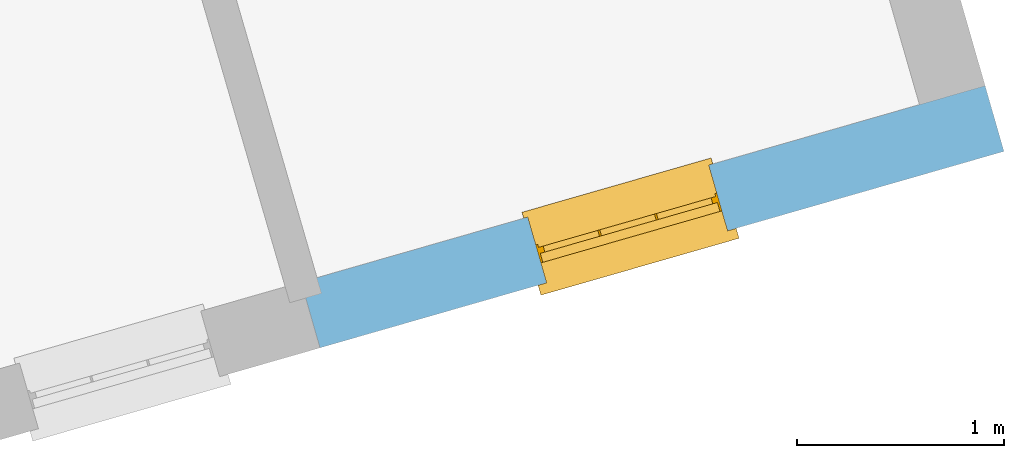
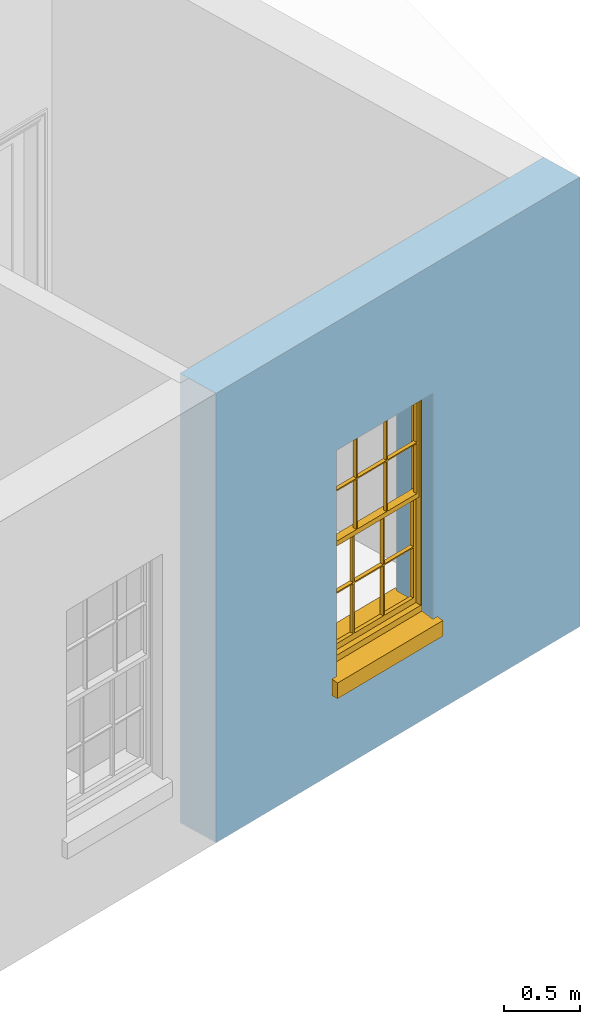
# One storey, part 5 of 10: 1 window, 1 opening, plus 1 element that does not belong to this part.
"""IFC2X3 building model written with IfcOpenShell, lengths in metres."""

from ifc_helpers import new_model, si_unit, frame, origin, place, context, subcontext, project, spatial, polyline, outline, extrude, faceted_brep, material, layer, layer_set, layer_usage, element, fill, save


model = new_model("IFC2X3")

# Units and contexts
model_context = context("Model", 3, world=origin())
body_context = subcontext(model_context, "Body", "Model", "MODEL_VIEW")
ifc_project = project(units=[si_unit("PLANEANGLEUNIT", "RADIAN"), si_unit("MASSUNIT", "GRAM", prefix="KILO"), si_unit("FORCEUNIT", "NEWTON", prefix="KILO"), si_unit("LENGTHUNIT", "METRE")], contexts=[model_context])

# Site, building, storey
site_placement = place(None, origin())
site = spatial("IfcSite", under=ifc_project, at=site_placement, CompositionType="ELEMENT")
building_placement = place(None, origin())
building = spatial("IfcBuilding", under=site, at=building_placement, Name="Building plot-15", CompositionType="ELEMENT")
storey_placement = place(None, frame((0.0, 0.0, 11.05)))
storey = spatial("IfcBuildingStorey", under=building, at=storey_placement, Name="Floor 2", CompositionType="ELEMENT", Elevation=11.05)

# Wall, opening, window
ifc_material = material(Name="Masonry")
ifc_layer = layer(ifc_material, 0.33, ventilated=False)
ifc_layer_set = layer_set([ifc_layer], Name="My Wall")
ifc_layer_usage = layer_usage(ifc_layer_set, "AXIS2", "NEGATIVE", 0.08)
wall_placement = place(storey_placement, origin())
wall = element("IfcWallStandardCase", 1, at=wall_placement, inside=storey, material=ifc_layer_usage, Name="exterior", context=body_context, shape_type="SweptSolid", body=[
    extrude(outline(polyline([(94.3616968609291, 52.4968545320888), (94.4527966416063, 52.1796781931848), (97.755192512736, 53.1281964231653), (97.6640927320589, 53.4453727620694), (94.3616968609291, 52.4968545320888)])), origin(), (0.0, 0.0, 1.0), 3.6),
])
opening_placement = place(storey_placement, frame((0.0, 0.0, 0.75)))
opening = element("IfcOpeningElement", 2, at=opening_placement, cuts=wall, Name="Opening", ObjectType="Opening", context=body_context, shape_type="SweptSolid", body=[
    extrude(outline(polyline([(95.5465331330367, 52.4938225421364), (96.4211709160752, 52.7450370888522), (96.3300711353981, 53.0622134277562), (95.4554333523596, 52.8109988810405), (95.5465331330367, 52.4938225421364)])), origin(), (0.0, 0.0, 1.0), 1.82),
])
window_placement = place(storey_placement, frame((95.4775181476753, 52.7341076473668, 0.75), z_axis=(0.0, 0.0, 1.0), x_axis=(0.874637783038438, 0.25121454671573, 0.0)))
window = element("IfcWindow", 3, at=window_placement, inside=storey, Name="bedroom outside window", OverallHeight=1.82, OverallWidth=0.91, context=body_context, shape_type="Brep", held_by="IfcProductRepresentation", body=[
    faceted_brep([(0.033125, -0.105, 0.975209), (0.01, -0.105, 0.975209), (0.033125, -0.105, 1.376042), (0.876875, -0.105, 0.975209), (0.876875, -0.105, 1.376042), (0.9, -0.105, 0.975209), (0.876875, -0.105, 1.386042), (0.876875, -0.105, 1.786875), (0.9, -0.105, 1.81), (0.033125, -0.105, 1.786875), (0.033125, -0.105, 1.386042), (0.01, -0.105, 1.81), (0.876875, -0.135, 1.376042), (0.876875, -0.135, 0.975209), (0.9, -0.135, 0.937083), (0.033125, -0.135, 1.786875), (0.01, -0.135, 1.81), (0.033125, -0.135, 1.386042), (0.01, -0.135, 0.937083), (0.033125, -0.135, 0.975209), (0.033125, -0.135, 1.376042), (0.876875, -0.135, 1.786875), (0.876875, -0.135, 1.386042), (0.9, -0.135, 1.81), (0.033125, -0.105, 0.937083), (0.01, -0.105, 0.937083), (0.033125, -0.105, 0.53625), (0.876875, -0.105, 0.937083), (0.876875, -0.105, 0.53625), (0.9, -0.105, 0.937083), (0.876875, -0.105, 0.52625), (0.876875, -0.105, 0.125417), (0.9, -0.105, 0.077167), (0.033125, -0.105, 0.125417), (0.033125, -0.105, 0.52625), (0.01, -0.105, 0.077167), (-0.0425, -0.25, 0.01), (-0.0425, -0.3, 0.001667), (0.0, -0.25, 0.01), (0.9525, -0.25, 0.01), (0.91, -0.25, 0.01), (0.9525, -0.3, 0.001667), (-0.02, 0.08, 0.077167), (0.0, 0.08, 0.077167), (-0.02, 0.11, 0.077167), (0.0, -0.06, 0.077167), (0.01, -0.06, 0.077167), (0.91, -0.06, 0.077167), (0.91, 0.08, 0.077167), (0.9, -0.06, 0.077167), (0.93, 0.08, 0.077167), (0.93, 0.11, 0.077167), (0.01, -0.075, 0.975209), (0.9, -0.075, 0.975209), (0.876875, -0.075, 0.125417), (0.876875, -0.075, 0.52625), (0.9, -0.075, 0.077167), (0.876875, -0.075, 0.53625), (0.876875, -0.075, 0.937083), (0.033125, -0.075, 0.125417), (0.01, -0.075, 0.077167), (0.033125, -0.075, 0.52625), (0.033125, -0.075, 0.937083), (0.033125, -0.075, 0.53625), (-0.02, 0.08, 0.052167), (-0.02, 0.11, 0.052167), (0.93, 0.11, 0.052167), (0.93, 0.08, 0.052167), (0.91, 0.08, 0.052167), (0.0, 0.08, 0.052167), (0.91, -0.15, 0.026667), (0.0, -0.15, 0.026667), (-0.0425, -0.3, -0.123333), (0.9525, -0.3, -0.123333), (-0.0425, -0.25, -0.123333), (0.9525, -0.25, -0.123333), (0.01, -0.06, 1.81), (0.9, -0.06, 1.81), (0.0, -0.06, 1.82), (0.91, -0.06, 1.82), (0.01, -0.15, 0.077167), (0.9, -0.15, 0.077167), (0.592292, -0.105, 0.125417), (0.592292, -0.075, 0.125417), (0.317708, -0.075, 0.125417), (0.317708, -0.105, 0.125417), (0.592292, -0.105, 0.53625), (0.317708, -0.105, 0.53625), (0.317708, -0.105, 0.52625), (0.592292, -0.105, 0.52625), (0.592292, -0.075, 0.53625), (0.317708, -0.075, 0.53625), (0.592292, -0.135, 1.386042), (0.592292, -0.105, 1.386042), (0.317708, -0.105, 1.386042), (0.317708, -0.135, 1.386042), (0.317708, -0.135, 1.376042), (0.592292, -0.135, 1.376042), (0.317708, -0.105, 1.376042), (0.592292, -0.105, 1.376042), (0.602292, -0.135, 1.376042), (0.592292, -0.135, 0.975209), (0.602292, -0.135, 0.975209), (0.602292, -0.105, 0.975209), (0.592292, -0.105, 0.975209), (0.602292, -0.105, 1.376042), (0.602292, -0.075, 0.53625), (0.602292, -0.105, 0.53625), (0.317708, -0.075, 0.52625), (0.307708, -0.075, 0.125417), (0.307708, -0.075, 0.52625), (0.602292, -0.075, 0.52625), (0.602292, -0.075, 0.125417), (0.592292, -0.075, 0.52625), (0.307708, -0.075, 0.53625), (0.317708, -0.075, 0.937083), (0.307708, -0.075, 0.937083), (0.602292, -0.075, 0.937083), (0.592292, -0.075, 0.937083), (0.307708, -0.105, 0.52625), (0.307708, -0.105, 0.125417), (0.307708, -0.105, 0.53625), (0.307708, -0.105, 0.937083), (0.592292, -0.105, 0.937083), (0.317708, -0.105, 0.937083), (0.602292, -0.105, 0.937083), (0.602292, -0.105, 0.52625), (0.602292, -0.105, 0.125417), (0.307708, -0.135, 1.386042), (0.307708, -0.135, 1.376042), (0.307708, -0.135, 0.975209), (0.317708, -0.135, 0.975209), (0.317708, -0.135, 1.786875), (0.307708, -0.135, 1.786875), (0.602292, -0.135, 1.786875), (0.592292, -0.135, 1.786875), (0.602292, -0.135, 1.386042), (0.602292, -0.105, 1.386042), (0.307708, -0.105, 1.386042), (0.307708, -0.105, 1.786875), (0.317708, -0.105, 1.786875), (0.592292, -0.105, 1.786875), (0.602292, -0.105, 1.786875), (0.307708, -0.105, 1.376042), (0.317708, -0.105, 0.975209), (0.307708, -0.105, 0.975209), (0.91, -0.15, 1.82), (0.9, -0.15, 1.81), (0.01, -0.15, 1.81), (0.0, -0.15, 1.82), (0.91, -0.25, 0.0), (0.0, -0.25, 0.0), (0.91, 0.08, 0.0), (0.0, 0.08, 0.0)], [[[0, 1, 2]], [[3, 4, 5]], [[6, 7, 8]], [[9, 10, 11]], [[12, 13, 14]], [[15, 16, 17]], [[18, 19, 20]], [[21, 22, 23]], [[24, 25, 26]], [[27, 28, 29]], [[30, 31, 32]], [[33, 34, 35]], [[14, 27, 29]], [[25, 24, 18]], [[36, 37, 38]], [[39, 40, 41]], [[42, 43, 44]], [[45, 46, 43]], [[47, 48, 49]], [[50, 51, 48]], [[1, 0, 52]], [[5, 53, 3]], [[54, 55, 56]], [[57, 58, 53]], [[59, 60, 61]], [[62, 63, 52]], [[48, 43, 46, 49]], [[51, 44, 43, 48]], [[64, 42, 44, 65]], [[65, 44, 51, 66]], [[66, 51, 50, 67]], [[65, 66, 68, 69]], [[60, 56, 49, 46]], [[70, 71, 38, 40]], [[37, 41, 40, 38]], [[37, 72, 73, 41]], [[74, 75, 73, 72]], [[8, 11, 76, 77]], [[76, 78, 79, 77]], [[32, 35, 80, 81]], [[81, 80, 71, 70]], [[82, 83, 84, 85]], [[86, 87, 88, 89]], [[86, 90, 91, 87]], [[92, 93, 94, 95]], [[92, 95, 96, 97]], [[96, 98, 99, 97]], [[100, 97, 101, 102]], [[103, 104, 99, 105]], [[97, 99, 104, 101]], [[102, 103, 105, 100]], [[28, 57, 106, 107]], [[108, 84, 109, 110]], [[111, 112, 83, 113]], [[114, 110, 61, 63]], [[90, 113, 108, 91]], [[115, 91, 114, 116]], [[117, 106, 90, 118]], [[111, 106, 57, 55]], [[119, 110, 109, 120]], [[34, 61, 110, 119]], [[89, 113, 83, 82]], [[88, 108, 113, 89]], [[85, 84, 108, 88]], [[121, 114, 63, 26]], [[122, 116, 114, 121]], [[123, 118, 90, 86]], [[87, 91, 115, 124]], [[107, 106, 117, 125]], [[126, 111, 55, 30]], [[127, 112, 111, 126]], [[126, 30, 28, 107]], [[88, 119, 120, 85]], [[126, 89, 82, 127]], [[125, 123, 86, 107]], [[121, 26, 34, 119]], [[124, 122, 121, 87]], [[128, 17, 20, 129]], [[96, 129, 130, 131]], [[132, 133, 128, 95]], [[134, 135, 92, 136]], [[100, 12, 22, 136]], [[137, 6, 4, 105]], [[94, 138, 139, 140]], [[137, 93, 141, 142]], [[99, 98, 94, 93]], [[143, 2, 10, 138]], [[144, 145, 143, 98]], [[129, 143, 145, 130]], [[20, 2, 143, 129]], [[131, 144, 98, 96]], [[128, 138, 10, 17]], [[133, 139, 138, 128]], [[135, 141, 93, 92]], [[95, 94, 140, 132]], [[22, 6, 137, 136]], [[136, 137, 142, 134]], [[100, 105, 4, 12]], [[107, 86, 89, 126]], [[106, 111, 113, 90]], [[91, 108, 110, 114]], [[87, 121, 119, 88]], [[97, 100, 136, 92]], [[129, 96, 95, 128]], [[98, 143, 138, 94]], [[105, 99, 93, 137]], [[131, 101, 104, 144]], [[124, 115, 118, 123]], [[132, 140, 141, 135]], [[120, 109, 59, 33]], [[15, 9, 139, 133]], [[134, 142, 7, 21]], [[31, 54, 112, 127]], [[36, 74, 72, 37]], [[39, 41, 73, 75]], [[18, 14, 101, 131]], [[23, 16, 132, 135]], [[83, 56, 60, 84]], [[52, 53, 118, 115]], [[53, 52, 144, 104]], [[11, 8, 141, 140]], [[14, 18, 124, 123]], [[2, 1, 11, 10]], [[8, 5, 4, 6]], [[57, 53, 56, 55]], [[60, 52, 63, 61]], [[26, 25, 35, 34]], [[32, 29, 28, 30]], [[14, 23, 22, 12]], [[18, 20, 17, 16]], [[19, 0, 2, 20]], [[17, 10, 9, 15]], [[12, 4, 3, 13]], [[21, 7, 6, 22]], [[27, 58, 57, 28]], [[30, 55, 54, 31]], [[33, 59, 61, 34]], [[26, 63, 62, 24]], [[5, 8, 77, 53]], [[76, 11, 1, 52]], [[46, 45, 78, 76]], [[49, 77, 79, 47]], [[70, 146, 147, 81]], [[71, 80, 148, 149]], [[19, 130, 145, 0]], [[102, 13, 3, 103]], [[116, 122, 24, 62]], [[29, 32, 81, 14]], [[80, 35, 25, 18]], [[60, 46, 76, 52]], [[77, 49, 56, 53]], [[23, 14, 81, 147]], [[16, 148, 80, 18]], [[35, 85, 120]], [[120, 33, 35]], [[127, 82, 32]], [[32, 31, 127]], [[32, 82, 85, 35]], [[102, 101, 14]], [[14, 13, 102]], [[18, 131, 130]], [[130, 19, 18]], [[134, 21, 23]], [[23, 135, 134]], [[16, 15, 133]], [[133, 132, 16]], [[11, 140, 139]], [[139, 9, 11]], [[142, 141, 8]], [[8, 7, 142]], [[23, 147, 148, 16]], [[146, 149, 148, 147]], [[52, 115, 116]], [[116, 62, 52]], [[118, 53, 117]], [[58, 117, 53]], [[27, 125, 117, 58]], [[56, 83, 112]], [[112, 54, 56]], [[109, 84, 60]], [[60, 59, 109]], [[125, 27, 14]], [[14, 123, 125]], [[122, 124, 18]], [[18, 24, 122]], [[145, 144, 52]], [[52, 0, 145]], [[103, 3, 53]], [[53, 104, 103]], [[79, 78, 149, 146]], [[78, 45, 71, 149]], [[146, 70, 47, 79]], [[150, 75, 74, 151]], [[68, 66, 67]], [[48, 68, 67, 50]], [[69, 64, 65]], [[42, 64, 69, 43]], [[69, 68, 152, 153]], [[70, 68, 48, 47]], [[150, 152, 68, 70]], [[43, 69, 71, 45]], [[69, 153, 151, 71]], [[152, 150, 151, 153]], [[38, 151, 74, 36]], [[71, 151, 38]], [[39, 75, 150, 40]], [[40, 150, 70]]]),
])
fill(opening, window)

save(model, "model.ifc")
